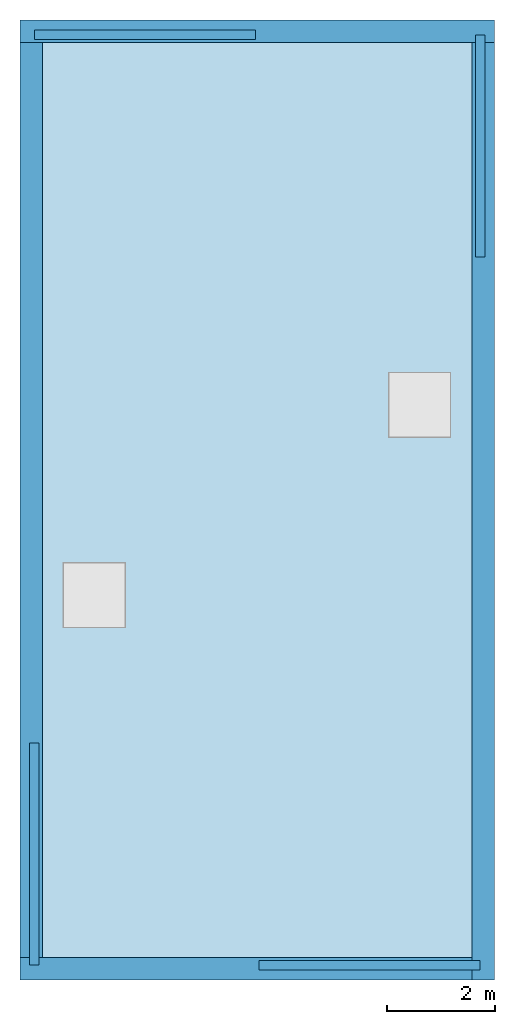
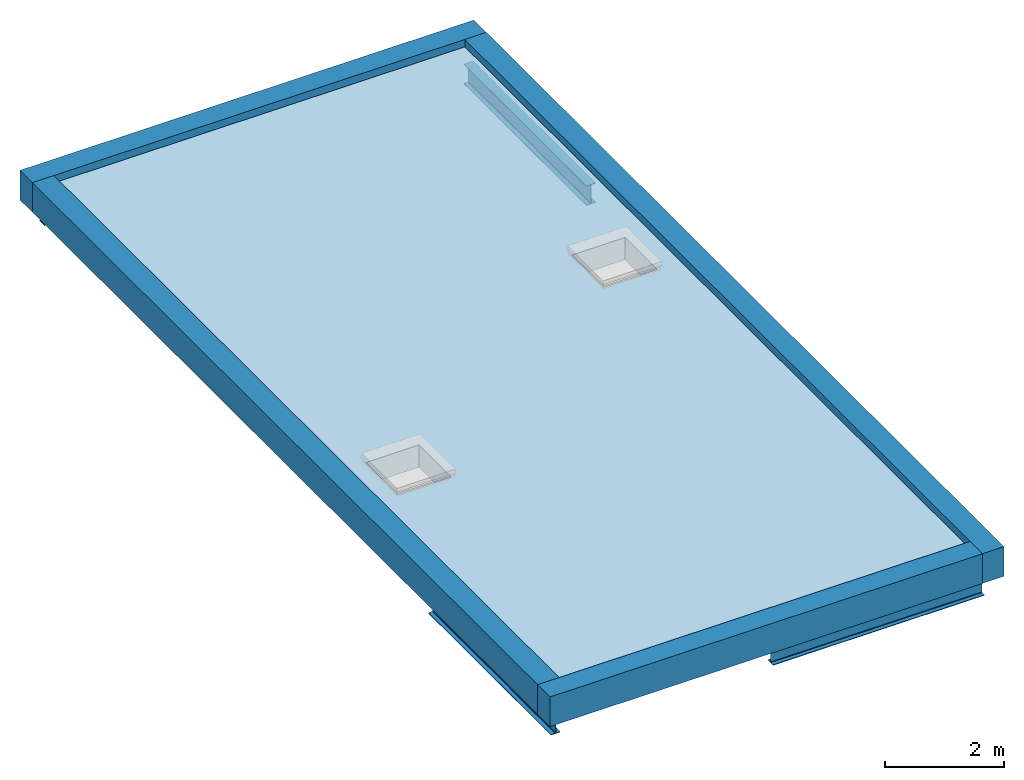
# One storey, part 1 of 2: 4 beams, 4 walls, 1 slab, 2 openings, 1 element without a shape of its own.
"""IFC2X3 building model written with IfcOpenShell, lengths in metres."""

from ifc_helpers import new_model, entity, si_unit, converted_unit, derived_unit, direction, frame, frame_2d, origin, place, context, subcontext, project, spatial, rectangle, i_section, extrude, material, layer, layer_set, layer_usage, type_object, element, aggregate, save


model = new_model("IFC2X3")

# Units and contexts
model_context = context("Model", 3, precision=1e-05, world=origin(), true_north=direction((6.12303176911189e-17, 1.0)))
body_context = subcontext(model_context, "Body", "Model", "MODEL_VIEW")
ifc_project = project(units=[derived_unit("USERDEFINED", [(si_unit("LENGTHUNIT", "METRE"), -2), (si_unit("TIMEUNIT", "SECOND"), -2), (si_unit("MASSUNIT", "GRAM", prefix="KILO"), 1)]), si_unit("FREQUENCYUNIT", "HERTZ"), si_unit("LENGTHUNIT", "METRE"), si_unit("ILLUMINANCEUNIT", "LUX"), derived_unit("LINEARVELOCITYUNIT", [(si_unit("TIMEUNIT", "SECOND"), -1), (si_unit("LENGTHUNIT", "METRE"), 1)]), si_unit("POWERUNIT", "WATT"), si_unit("LUMINOUSINTENSITYUNIT", "CANDELA"), si_unit("AREAUNIT", "SQUARE_METRE"), si_unit("VOLUMEUNIT", "CUBIC_METRE"), si_unit("ELECTRICVOLTAGEUNIT", "VOLT"), si_unit("PRESSUREUNIT", "PASCAL"), converted_unit("PLANEANGLEUNIT", "DEGREE", entity("IfcRatioMeasure", 0.0174532925199433), si_unit("PLANEANGLEUNIT", "RADIAN"), dimensions=[0, 0, 0, 0, 0, 0, 0]), si_unit("THERMODYNAMICTEMPERATUREUNIT", "DEGREE_CELSIUS"), si_unit("MASSUNIT", "GRAM", prefix="KILO"), derived_unit("VOLUMETRICFLOWRATEUNIT", [(si_unit("LENGTHUNIT", "METRE"), 3), (si_unit("TIMEUNIT", "SECOND"), -1)]), si_unit("TIMEUNIT", "SECOND"), si_unit("LUMINOUSFLUXUNIT", "LUMEN"), derived_unit("USERDEFINED", [(si_unit("LUMINOUSFLUXUNIT", "LUMEN"), 1), (si_unit("TIMEUNIT", "SECOND"), 3), (si_unit("MASSUNIT", "GRAM", prefix="KILO"), -1), (si_unit("LENGTHUNIT", "METRE"), -2)]), si_unit("FORCEUNIT", "NEWTON", prefix="KILO"), si_unit("ELECTRICCURRENTUNIT", "AMPERE"), derived_unit("THERMALTRANSMITTANCEUNIT", [(si_unit("TIMEUNIT", "SECOND"), -3), (si_unit("THERMODYNAMICTEMPERATUREUNIT", "KELVIN"), -1), (si_unit("MASSUNIT", "GRAM", prefix="KILO"), 1)])], contexts=[model_context])

# Site, building, storey
site_placement = place(None, origin())
site = spatial("IfcSite", under=ifc_project, at=site_placement, CompositionType="ELEMENT")
building_placement = place(site_placement, origin())
building = spatial("IfcBuilding", under=site, at=building_placement, CompositionType="ELEMENT")
storey_placement = place(building_placement, frame((0.0, 0.0, 6.0)))
storey = spatial("IfcBuildingStorey", under=building, at=storey_placement, Name="Roof", CompositionType="ELEMENT", Elevation=6.00000000000039)

# Beams
ifc_material_1 = material(Name="Metal - Steel - 345 MPa")
beam_1_placement = place(storey_placement, frame((0.266612879575049, -13.4017200713696, 0.0), z_axis=(0.0, 0.0, 1.0), x_axis=(0.0, -1.0, 0.0)))
element("IfcBeam", 1, at=beam_1_placement, inside=storey, material=ifc_material_1, context=body_context, shape_type="SweptSolid", body=[
    extrude(i_section(OverallWidth=0.178, OverallDepth=0.407000000000001, WebThickness=0.00770000000000008, FlangeThickness=0.0128000000000014, FilletRadius=0.0172000000000005, at=frame_2d((0.0, 4.85722573273506e-17), x_axis=(0.0, 1.0))), frame((0.0, 0.0, -0.203500000000006), z_axis=(1.0, 0.0, 0.0), x_axis=(0.0, 0.0, -1.0)), (0.0, 0.0, 1.0), 4.12127992863035),
])
beam_2_placement = place(storey_placement, frame((4.42895432874426, -17.5287668629737, 0.0)))
element("IfcBeam", 2, at=beam_2_placement, inside=storey, material=ifc_material_1, context=body_context, shape_type="SweptSolid", body=[
    extrude(i_section(OverallWidth=0.178000000000012, OverallDepth=0.407000000000001, WebThickness=0.00769999999964814, FlangeThickness=0.0128000000000014, FilletRadius=0.0172000000000019, at=frame_2d((0.0, -3.25434124093249e-15), x_axis=(0.0, 1.0))), frame((0.0, 0.0, -0.203500000000006), z_axis=(1.0, 0.0, 0.0), x_axis=(0.0, 0.0, -1.0)), (0.0, 0.0, 1.0), 4.1),
])
beam_3_placement = place(storey_placement, frame((8.53338712042497, -4.39827992863039, 0.0), z_axis=(0.0, 0.0, 1.0), x_axis=(0.0, 1.0, 0.0)))
element("IfcBeam", 3, at=beam_3_placement, inside=storey, material=ifc_material_1, context=body_context, shape_type="SweptSolid", body=[
    extrude(i_section(OverallWidth=0.178000000000001, OverallDepth=0.407000000000001, WebThickness=0.00770000000000041, FlangeThickness=0.0128000000000014, FilletRadius=0.017200000000001, at=frame_2d((0.0, 1.08246744900953e-15), x_axis=(0.0, 1.0))), frame((0.0, 0.0, -0.203500000000006), z_axis=(1.0, 0.0, 0.0), x_axis=(0.0, 0.0, -1.0)), (0.0, 0.0, 1.0), 4.12127992863035),
])
beam_4_placement = place(storey_placement, frame((4.37104567125577, -0.271233137026328, 0.0), z_axis=(0.0, 0.0, 1.0), x_axis=(-1.0, 0.0, 0.0)))
element("IfcBeam", 4, at=beam_4_placement, inside=storey, material=ifc_material_1, context=body_context, shape_type="SweptSolid", body=[
    extrude(i_section(OverallWidth=0.178000000000026, OverallDepth=0.407000000000001, WebThickness=0.00769999999928911, FlangeThickness=0.0128000000000014, FilletRadius=0.0172000000000005, at=frame_2d((0.0, -3.46944695195361e-17), x_axis=(0.0, 1.0))), frame((0.0, 0.0, -0.203500000000006), z_axis=(1.0, 0.0, 0.0), x_axis=(0.0, 0.0, -1.0)), (0.0, 0.0, 1.0), 4.1),
])

# Roof, slab, openings
roof_placement = place(storey_placement, origin())
roof = element("IfcRoof", 5, at=roof_placement, inside=storey, ShapeType="NOTDEFINED")
slab_placement = place(storey_placement, origin())
slab = element("IfcSlab", 6, at=slab_placement, PredefinedType="ROOF", context=body_context, shape_type="SweptSolid", body=[
    extrude(rectangle(XDim=16.966, YDim=7.966, at=frame_2d((0.0, -6.66133814775094e-15), x_axis=(1.0, 0.0))), frame((4.39999999999999, -8.9, 0.0), z_axis=(0.0, 0.0, 1.0), x_axis=(0.0, -1.0, 0.0)), (0.0, 0.0, 1.0), 0.457),
])
opening_1_placement = place(storey_placement, origin())
element("IfcOpeningElement", 7, at=opening_1_placement, cuts=slab, ObjectType="Opening", context=body_context, shape_type="SweptSolid", body=[
    extrude(rectangle(XDim=1.0291, YDim=1.08109999999996, at=frame_2d((5.55111512312578e-17, 1.11022302462516e-15), x_axis=(1.0, 0.0))), frame((1.37600000000002, -10.665, 0.0), z_axis=(0.0, 0.0, 1.0), x_axis=(-1.0, 0.0, 0.0)), (0.0, 0.0, 1.0), 0.457),
])
opening_2_placement = place(storey_placement, origin())
element("IfcOpeningElement", 8, at=opening_2_placement, cuts=slab, ObjectType="Opening", context=body_context, shape_type="SweptSolid", body=[
    extrude(rectangle(XDim=1.0291, YDim=1.08109999999996, at=frame_2d((4.9960036108132e-16, 0.0), x_axis=(1.0, 0.0))), frame((7.40900000000003, -7.13500000000003, 0.0), z_axis=(0.0, 0.0, 1.0), x_axis=(-1.0, 0.0, 0.0)), (0.0, 0.0, 1.0), 0.457),
])
aggregate(roof, [slab])

# Walls
ifc_material_2 = material(Name="Masonry - Brick")
ifc_layer_1 = layer(ifc_material_2, 0.092)
ifc_material_3 = material(Name="Misc. Air Layers - Air Space")
ifc_layer_2 = layer(ifc_material_3, 0.025)
ifc_material_4 = material(Name="Insulation / Thermal Barriers - Rigid insulation")
ifc_layer_3 = layer(ifc_material_4, 0.05)
ifc_material_5 = material(Name="Masonry - Concrete Block")
ifc_layer_4 = layer(ifc_material_5, 0.193)
ifc_material_6 = material(Name="Metal - Stud Layer")
ifc_layer_5 = layer(ifc_material_6, 0.041)
ifc_material_7 = material(Name="Plasterboard")
ifc_layer_6 = layer(ifc_material_7, 0.016)
ifc_layer_set = layer_set([ifc_layer_1, ifc_layer_2, ifc_layer_3, ifc_layer_4, ifc_layer_5, ifc_layer_6], Name="Mur de base:Exterior - Brick on Block")
ifc_layer_usage_1 = layer_usage(ifc_layer_set, "AXIS2", "NEGATIVE", 0.2085)
wall_type = type_object("IfcWallType", Name="Mur de base:Exterior - Brick on Block", PredefinedType="STANDARD", material=ifc_layer_set)
wall_1_placement = place(storey_placement, frame((0.0, -0.2085, 0.0)))
element("IfcWallStandardCase", 9, at=wall_1_placement, inside=storey, type_object=wall_type, material=ifc_layer_usage_1, Name="Mur de base:Exterior - Brick on Block", ObjectType="Mur de base:Exterior - Brick on Block", context=body_context, shape_type="SweptSolid", body=[
    extrude(rectangle(XDim=8.8, YDim=0.417, at=frame_2d((4.4, 0.0), x_axis=(-1.0, 0.0))), origin(), (0.0, 0.0, 1.0), 0.609),
])
ifc_layer_usage_2 = layer_usage(ifc_layer_set, "AXIS2", "NEGATIVE", 0.2085)
wall_2_placement = place(storey_placement, frame((8.5915, -0.417000000000028, 0.0), z_axis=(0.0, 0.0, 1.0), x_axis=(0.0, -1.0, 0.0)))
element("IfcWallStandardCase", 10, at=wall_2_placement, inside=storey, type_object=wall_type, material=ifc_layer_usage_2, Name="Mur de base:Exterior - Brick on Block", ObjectType="Mur de base:Exterior - Brick on Block", context=body_context, shape_type="SweptSolid", body=[
    extrude(rectangle(XDim=17.383, YDim=0.417, at=frame_2d((8.69149999999999, 2.08166817117217e-16), x_axis=(-1.0, 0.0))), origin(), (0.0, 0.0, 1.0), 0.609),
])
ifc_layer_usage_3 = layer_usage(ifc_layer_set, "AXIS2", "NEGATIVE", 0.2085)
wall_3_placement = place(storey_placement, frame((8.38299999999997, -17.5915, 0.0), z_axis=(0.0, 0.0, 1.0), x_axis=(-1.0, 0.0, 0.0)))
element("IfcWallStandardCase", 11, at=wall_3_placement, inside=storey, type_object=wall_type, material=ifc_layer_usage_3, Name="Mur de base:Exterior - Brick on Block", ObjectType="Mur de base:Exterior - Brick on Block", context=body_context, shape_type="SweptSolid", body=[
    extrude(rectangle(XDim=8.38299999999997, YDim=0.417, at=frame_2d((4.19149999999999, 4.30211422042248e-16), x_axis=(-1.0, 0.0))), origin(), (0.0, 0.0, 1.0), 0.609),
])
ifc_layer_usage_4 = layer_usage(ifc_layer_set, "AXIS2", "NEGATIVE", 0.2085)
wall_4_placement = place(storey_placement, frame((0.208499999999999, -17.383, 0.0), z_axis=(0.0, 0.0, 1.0), x_axis=(0.0, 1.0, 0.0)))
element("IfcWallStandardCase", 12, at=wall_4_placement, inside=storey, type_object=wall_type, material=ifc_layer_usage_4, Name="Mur de base:Exterior - Brick on Block", ObjectType="Mur de base:Exterior - Brick on Block", context=body_context, shape_type="SweptSolid", body=[
    extrude(rectangle(XDim=16.966, YDim=0.417, at=frame_2d((8.48299999999999, 2.77555756156289e-17), x_axis=(-1.0, 0.0))), origin(), (0.0, 0.0, 1.0), 0.609),
])

save(model, "model.ifc")
